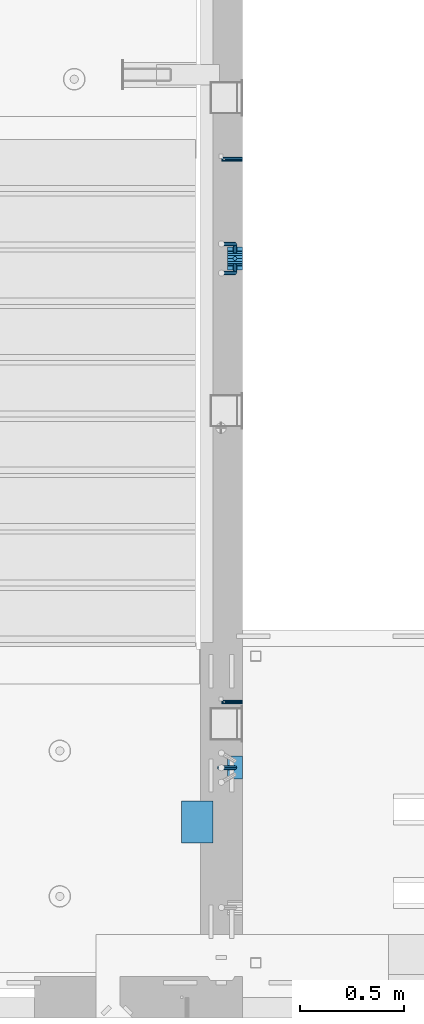
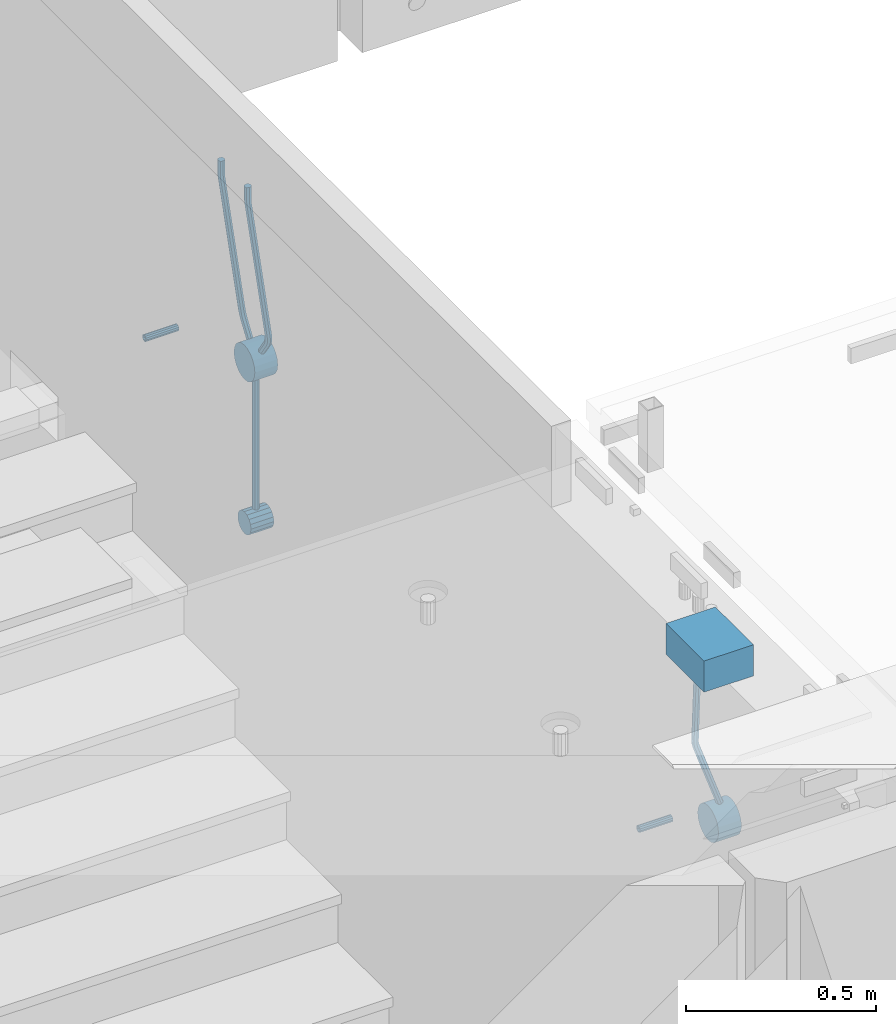
# One storey, part 104 of 264: 10 beams, 4 elements without a shape of their own.
"""IFC2X3 building model written with IfcOpenShell, lengths in millimetres."""

from ifc_helpers import new_model, si_unit, frame, origin_with_axes, place, context, subcontext, project, spatial, faceted_brep, material, type_object, element, aggregate, save


model = new_model("IFC2X3")

# Units and contexts
model_context = context("Model", 3, precision=1e-05, world=origin_with_axes())
body_context = subcontext(model_context, "Body", "Model", "MODEL_VIEW")
ifc_project = project(units=[si_unit("LENGTHUNIT", "METRE", prefix="MILLI"), si_unit("AREAUNIT", "SQUARE_METRE"), si_unit("VOLUMEUNIT", "CUBIC_METRE"), si_unit("MASSUNIT", "GRAM", prefix="KILO"), si_unit("TIMEUNIT", "SECOND"), si_unit("PLANEANGLEUNIT", "RADIAN"), si_unit("SOLIDANGLEUNIT", "STERADIAN"), si_unit("THERMODYNAMICTEMPERATUREUNIT", "DEGREE_CELSIUS"), si_unit("LUMINOUSINTENSITYUNIT", "LUMEN")], contexts=[model_context])

# Site, building, storey
site_placement = place(None, origin_with_axes())
site = spatial("IfcSite", under=ifc_project, at=site_placement, CompositionType="ELEMENT")
building_placement = place(site_placement, origin_with_axes())
building = spatial("IfcBuilding", under=site, at=building_placement, CompositionType="ELEMENT")
storey_placement = place(building_placement, origin_with_axes())
storey = spatial("IfcBuildingStorey", under=building, at=storey_placement, Name="K", CompositionType="ELEMENT", Elevation=0.0)

# Assemblies, beams
assembly_1_placement = place(storey_placement, origin_with_axes())
assembly_1 = element("IfcElementAssembly", 1, at=assembly_1_placement, inside=storey, AssemblyPlace="NOTDEFINED", PredefinedType="REINFORCEMENT_UNIT")
assembly_2_placement = place(assembly_1_placement, origin_with_axes())
assembly_2 = element("IfcElementAssembly", 2, at=assembly_2_placement, Name="Steel Assembly", AssemblyPlace="NOTDEFINED", PredefinedType="RIGID_FRAME")
ifc_material_1 = material(Name="STEEL/Steel_Undefined")
beam_type_1 = type_object("IfcBeamType", PredefinedType="NOTDEFINED")
beam_1_placement = place(assembly_2_placement, frame((22410.0, 19195.0015403676, 80575.0), z_axis=(0.0, 1.0, 0.0), x_axis=(-1.0, 3.00000001838171e-08, 0.0)))
beam_1 = element("IfcBeam", 3, at=beam_1_placement, type_object=beam_type_1, material=ifc_material_1, Name="M16", context=body_context, shape_type="Brep", body=[
    faceted_brep([(0.0, -8.49999999999272, -1.45519152283669e-11), (0.0, -7.36121593215648, 4.24999999998545), (100.000000000262, -7.36121593215648, 4.24999999998545), (100.000000000262, -8.49999999999272, -1.45519152283669e-11), (0.0, -4.24999999998545, 7.36121593216376), (100.000000000262, -4.24999999998545, 7.36121593216376), (0.0, 1.45519152283669e-11, 8.49999999998545), (100.000000000262, 1.45519152283669e-11, 8.49999999998545), (0.0, 4.25000000001455, 7.36121593216376), (100.000000000262, 4.25000000001455, 7.36121593216376), (0.0, 7.36121593217104, 4.24999999998545), (100.000000000262, 7.36121593217104, 4.24999999998545), (0.0, 8.50000000000728, 0.0), (100.000000000262, 8.50000000000728, 0.0), (0.0, 7.36121593217104, -4.25000000001455), (100.000000000262, 7.36121593217104, -4.25000000001455), (0.0, 4.25000000000728, -7.36121593219286), (100.000000000262, 4.25000000000728, -7.36121593219286), (0.0, 7.27595761418343e-12, -8.5), (100.000000000262, 7.27595761418343e-12, -8.5), (0.0, -4.24999999999272, -7.36121593217831), (100.000000000262, -4.24999999999272, -7.36121593217831), (0.0, -7.36121593215648, -4.25), (100.000000000262, -7.36121593215648, -4.25), (0.0, -10.4999999999927, -1.45519152283669e-11), (0.0, -9.09326673972828, -5.25000000001455), (100.000000000262, -9.09326673972828, -5.25000000001455), (100.000000000262, -10.4999999999927, -1.45519152283669e-11), (0.0, -5.24999999998545, -9.09326673974283), (100.000000000262, -5.24999999998545, -9.09326673974283), (0.0, 7.27595761418343e-12, -10.5), (100.000000000262, 7.27595761418343e-12, -10.5), (0.0, 5.25000000001455, -9.09326673975738), (100.000000000262, 5.25000000001455, -9.09326673975738), (0.0, 9.09326673975011, -5.25000000001455), (100.000000000262, 9.09326673975011, -5.25000000001455), (0.0, 10.5000000000073, -1.45519152283669e-11), (100.000000000262, 10.5000000000073, -1.45519152283669e-11), (0.0, 9.09326673975011, 5.25), (100.000000000262, 9.09326673975011, 5.25), (0.0, 5.25000000000728, 9.09326673972828), (100.000000000262, 5.25000000000728, 9.09326673972828), (0.0, 1.45519152283669e-11, 10.4999999999854), (100.000000000262, 1.45519152283669e-11, 10.4999999999854), (0.0, -5.24999999999272, 9.09326673972828), (100.000000000262, -5.24999999999272, 9.09326673972828), (0.0, -9.09326673972828, 5.24999999998545), (100.000000000262, -9.09326673972828, 5.24999999998545)], [[[0, 1, 2, 3]], [[1, 4, 5, 2]], [[4, 6, 7, 5]], [[6, 8, 9, 7]], [[8, 10, 11, 9]], [[10, 12, 13, 11]], [[12, 14, 15, 13]], [[14, 16, 17, 15]], [[16, 18, 19, 17]], [[18, 20, 21, 19]], [[20, 22, 23, 21]], [[22, 0, 3, 23]], [[24, 25, 26, 27]], [[25, 28, 29, 26]], [[28, 30, 31, 29]], [[30, 32, 33, 31]], [[32, 34, 35, 33]], [[34, 36, 37, 35]], [[36, 38, 39, 37]], [[38, 40, 41, 39]], [[40, 42, 43, 41]], [[42, 44, 45, 43]], [[44, 46, 47, 45]], [[46, 24, 27, 47]], [[29, 31, 33, 35, 37, 39, 41, 43, 45, 47, 27, 26], [5, 7, 9, 11, 13, 15, 17, 19, 21, 23, 3, 2]], [[46, 44, 42, 40, 38, 36, 34, 32, 30, 28, 25, 24], [22, 20, 18, 16, 14, 12, 10, 8, 6, 4, 1, 0]]]),
])
aggregate(assembly_2, [beam_1])
assembly_3_placement = place(assembly_1_placement, origin_with_axes())
assembly_3 = element("IfcElementAssembly", 4, at=assembly_3_placement, Name="Steel Assembly", AssemblyPlace="NOTDEFINED", PredefinedType="RIGID_FRAME")
beam_2_placement = place(assembly_3_placement, frame((22410.0, 16595.0015403676, 80575.0), z_axis=(0.0, -1.0, 0.0), x_axis=(-1.0, 3.00000001838171e-08, 0.0)))
beam_2 = element("IfcBeam", 5, at=beam_2_placement, type_object=beam_type_1, material=ifc_material_1, Name="M16", context=body_context, shape_type="Brep", body=[
    faceted_brep([(0.0, -8.49999999999272, -1.45519152283669e-11), (0.0, -7.36121593215648, 4.24999999998545), (100.000000000262, -7.36121593215648, 4.24999999998545), (100.000000000262, -8.49999999999272, -1.45519152283669e-11), (0.0, -4.24999999998545, 7.36121593216376), (100.000000000262, -4.24999999998545, 7.36121593216376), (0.0, 1.45519152283669e-11, 8.49999999998545), (100.000000000262, 1.45519152283669e-11, 8.49999999998545), (0.0, 4.25000000001455, 7.36121593216376), (100.000000000262, 4.25000000001455, 7.36121593216376), (0.0, 7.36121593217104, 4.24999999998545), (100.000000000262, 7.36121593217104, 4.24999999998545), (0.0, 8.50000000000728, 0.0), (100.000000000262, 8.50000000000728, 0.0), (0.0, 7.36121593217104, -4.25000000001455), (100.000000000262, 7.36121593217104, -4.25000000001455), (0.0, 4.25000000000728, -7.36121593219286), (100.000000000262, 4.25000000000728, -7.36121593219286), (0.0, 7.27595761418343e-12, -8.5), (100.000000000262, 7.27595761418343e-12, -8.5), (0.0, -4.24999999999272, -7.36121593217831), (100.000000000262, -4.24999999999272, -7.36121593217831), (0.0, -7.36121593215648, -4.25), (100.000000000262, -7.36121593215648, -4.25), (0.0, -10.4999999999927, -1.45519152283669e-11), (0.0, -9.09326673972828, -5.25000000001455), (100.000000000262, -9.09326673972828, -5.25000000001455), (100.000000000262, -10.4999999999927, -1.45519152283669e-11), (0.0, -5.24999999998545, -9.09326673974283), (100.000000000262, -5.24999999998545, -9.09326673974283), (0.0, 7.27595761418343e-12, -10.5), (100.000000000262, 7.27595761418343e-12, -10.5), (0.0, 5.25000000001455, -9.09326673975738), (100.000000000262, 5.25000000001455, -9.09326673975738), (0.0, 9.09326673975011, -5.25000000001455), (100.000000000262, 9.09326673975011, -5.25000000001455), (0.0, 10.5000000000073, -1.45519152283669e-11), (100.000000000262, 10.5000000000073, -1.45519152283669e-11), (0.0, 9.09326673975011, 5.25), (100.000000000262, 9.09326673975011, 5.25), (0.0, 5.25000000000728, 9.09326673972828), (100.000000000262, 5.25000000000728, 9.09326673972828), (0.0, 1.45519152283669e-11, 10.4999999999854), (100.000000000262, 1.45519152283669e-11, 10.4999999999854), (0.0, -5.24999999999272, 9.09326673972828), (100.000000000262, -5.24999999999272, 9.09326673972828), (0.0, -9.09326673972828, 5.24999999998545), (100.000000000262, -9.09326673972828, 5.24999999998545)], [[[0, 1, 2, 3]], [[1, 4, 5, 2]], [[4, 6, 7, 5]], [[6, 8, 9, 7]], [[8, 10, 11, 9]], [[10, 12, 13, 11]], [[12, 14, 15, 13]], [[14, 16, 17, 15]], [[16, 18, 19, 17]], [[18, 20, 21, 19]], [[20, 22, 23, 21]], [[22, 0, 3, 23]], [[24, 25, 26, 27]], [[25, 28, 29, 26]], [[28, 30, 31, 29]], [[30, 32, 33, 31]], [[32, 34, 35, 33]], [[34, 36, 37, 35]], [[36, 38, 39, 37]], [[38, 40, 41, 39]], [[40, 42, 43, 41]], [[42, 44, 45, 43]], [[44, 46, 47, 45]], [[46, 24, 27, 47]], [[29, 31, 33, 35, 37, 39, 41, 43, 45, 47, 27, 26], [5, 7, 9, 11, 13, 15, 17, 19, 21, 23, 3, 2]], [[46, 44, 42, 40, 38, 36, 34, 32, 30, 28, 25, 24], [22, 20, 18, 16, 14, 12, 10, 8, 6, 4, 1, 0]]]),
])
aggregate(assembly_3, [beam_2])
ifc_material_2 = material()
beam_type_2 = type_object("IfcBeamType", Name="D20", PredefinedType="NOTDEFINED")
beam_3_placement = place(assembly_1_placement, frame((22375.0, 18720.0024460395, 80295.0), z_axis=(-1.0, 3.00000001838171e-08, 0.0), x_axis=(0.0, 0.0, 1.0)))
beam_3 = element("IfcBeam", 6, at=beam_3_placement, type_object=beam_type_2, material=ifc_material_2, Name="JM20", ObjectType="D20", context=body_context, shape_type="Brep", body=[
    faceted_brep([(0.0, -10.0, 0.0), (-4.19531716033816e-08, -7.07106781186667, -7.07106781187031), (425.0, -7.07106781186667, -7.07106781186667), (425.0, -10.0, 0.0), (0.0, 0.0, -10.0), (425.0, 0.0, -10.0), (4.196772351861e-08, 7.07106781186303, -7.07106781186667), (425.0, 7.07106781186667, -7.07106781186667), (0.0, 10.0, 0.0), (425.0, 10.0, 0.0), (4.196772351861e-08, 7.07106781185939, 7.07106781185939), (425.0, 7.07106781186667, 7.07106781186667), (0.0, 0.0, 10.0), (425.0, 0.0, 10.0), (-4.19531716033816e-08, -7.07106781187031, 7.07106781185939), (425.0, -7.07106781186667, 7.07106781186667)], [[[0, 1, 2, 3]], [[1, 4, 5, 2]], [[4, 6, 7, 5]], [[6, 8, 9, 7]], [[8, 10, 11, 9]], [[10, 12, 13, 11]], [[12, 14, 15, 13]], [[14, 0, 3, 15]], [[5, 7, 9, 11, 13, 15, 3, 2]], [[14, 12, 10, 8, 6, 4, 1, 0]]]),
])
beam_4_placement = place(assembly_1_placement, frame((22375.0, 18687.6724460395, 80819.5), z_axis=(0.0, 0.827411434811092, 0.56159622287178), x_axis=(0.0, -0.561596222871772, 0.827411434811098)))
beam_4 = element("IfcBeam", 7, at=beam_4_placement, type_object=beam_type_2, material=ifc_material_2, Name="JM20", ObjectType="D20", context=body_context, shape_type="Brep", body=[
    faceted_brep([(0.0, -10.0, 0.0), (-4.19531716033816e-08, -7.07106781186667, -7.07106781187031), (51.3337046376182, -7.07106781186667, -7.07106782787741), (51.3337046409506, -9.99999999991269, -1.54977897182107e-08), (0.0, 0.0, -10.0), (51.3337046367014, 0.0, -10.0000000160071), (4.196772351861e-08, 7.07106781186303, -7.07106781186667), (51.3337046376182, 7.07106781186667, -7.07106782787741), (0.0, 10.0, 0.0), (51.3337046398156, 10.0, -1.60071067512035e-08), (4.196772351861e-08, 7.07106781185939, 7.07106781185939), (51.3337046420129, 7.07106781186667, 7.07106779584865), (0.0, 0.0, 10.0), (51.3337046429369, 0.0, 9.99999998399289), (-4.19531716033816e-08, -7.07106781187031, 7.07106781185939), (51.3337046420129, -7.07106781186667, 7.07106779584865), (69.2660488444162, -0.659091922268999, -7.32357754200348), (67.9041481351378, -7.68010393845179, -4.59791056146787), (65.6318046158776, -10.525517583621, 2.13400743270176), (63.7801263017391, -7.52852813498976, 8.92871018030564), (63.4338012359876, -0.444731365285406, 11.8059529640959), (64.7957019452297, 6.57628065089375, 9.08028598354576), (67.0680454645553, 9.4216942960702, 2.34836798937613), (68.9197237786866, 6.42470484744263, -4.44633475822775), (84.8821003096673, 4.54529190707035, 3.1855339796457), (85.5427757165526, -2.57551652551047, 0.458587145571073), (81.3497012897642, 7.74016969877266, 9.17665714836039), (77.0148100949955, 5.13760076933977, 14.9224379533844), (74.4167471958863, -1.73786529938297, 17.0570759255497), (75.0774226027788, -8.85867373196015, 14.3301290915115), (78.609821621445, -12.0535515238407, 8.3390059217345), (82.9447128173924, -9.45098259421866, 2.59322511772189), (456.104653264258, -71.822885658672, 255.871345609288), (451.769762084536, -74.4254545888944, 261.617126423276), (458.702716163367, -64.9474195899311, 253.736707637021), (458.042040756467, -57.8266111573103, 256.463654471001), (454.509641736608, -54.6317333655752, 262.454777639738), (450.174750541912, -57.2343022950008, 268.200558444849), (447.576687642802, -64.1097683637381, 270.335196417116), (448.237363049702, -71.2305767963589, 267.608249583143), (462.606852955585, -72.3637176989323, 260.284640654914), (458.569771733186, -74.9910575049726, 266.232556636794), (464.41816149011, -65.4228119344734, 257.616001989816), (462.942657378102, -58.2342286728781, 259.789892987465), (459.044670917043, -55.0089424945145, 265.532877784543), (455.007589709916, -57.6362823001473, 271.480793775474), (453.196281175427, -64.5771880646025, 274.149432440572), (454.671785287435, -71.7657713262015, 271.975541442938), (501.1302431886, -72.3637176993616, 286.431959314003), (497.093161981102, -74.9910575049726, 292.379875304716), (502.941551724049, -65.4228119349536, 283.763320649487), (501.466047613016, -58.2342286733801, 285.93721164779), (497.568061152415, -55.0089424950274, 291.680196445202), (493.530979944895, -57.6362823006384, 297.628112435916), (491.719671409453, -64.5771880650464, 300.296751100424), (493.195175520486, -71.7657713266199, 298.122860102128)], [[[0, 1, 2, 3]], [[1, 4, 5, 2]], [[4, 6, 7, 5]], [[6, 8, 9, 7]], [[8, 10, 11, 9]], [[10, 12, 13, 11]], [[12, 14, 15, 13]], [[14, 0, 3, 15]], [[14, 12, 10, 8, 6, 4, 1, 0]], [[2, 5, 16, 17]], [[3, 2, 17, 18]], [[15, 3, 18, 19]], [[13, 15, 19, 20]], [[11, 13, 20, 21]], [[9, 11, 21, 22]], [[7, 9, 22, 23]], [[5, 7, 23, 16]], [[23, 24, 25, 16]], [[22, 26, 24, 23]], [[21, 27, 26, 22]], [[20, 28, 27, 21]], [[19, 29, 28, 20]], [[18, 30, 29, 19]], [[17, 31, 30, 18]], [[16, 25, 31, 17]], [[30, 31, 32, 33]], [[31, 25, 34, 32]], [[25, 24, 35, 34]], [[24, 26, 36, 35]], [[26, 27, 37, 36]], [[27, 28, 38, 37]], [[28, 29, 39, 38]], [[29, 30, 33, 39]], [[33, 32, 40, 41]], [[32, 34, 42, 40]], [[34, 35, 43, 42]], [[35, 36, 44, 43]], [[36, 37, 45, 44]], [[37, 38, 46, 45]], [[38, 39, 47, 46]], [[39, 33, 41, 47]], [[41, 40, 48, 49]], [[40, 42, 50, 48]], [[42, 43, 51, 50]], [[43, 44, 52, 51]], [[44, 45, 53, 52]], [[45, 46, 54, 53]], [[46, 47, 55, 54]], [[47, 41, 49, 55]], [[50, 51, 52, 53, 54, 55, 49, 48]]]),
])
beam_5_placement = place(assembly_1_placement, frame((22375.0, 18752.3324460395, 80819.5), z_axis=(0.0, -0.827411461133416, 0.561596184090549), x_axis=(0.0, 0.561596184090567, 0.827411461133404)))
beam_5 = element("IfcBeam", 8, at=beam_5_placement, type_object=beam_type_2, material=ifc_material_2, Name="JM20", ObjectType="D20", context=body_context, shape_type="Brep", body=[
    faceted_brep([(0.0, -10.0, 0.0), (-4.19531716033816e-08, -7.07106781186667, -7.07106781187031), (51.3337046376182, -7.07106781186667, -7.07106782787741), (51.3337046409506, -9.99999999991269, -1.54977897182107e-08), (0.0, 0.0, -10.0), (51.3337046367014, 0.0, -10.0000000160071), (4.196772351861e-08, 7.07106781186303, -7.07106781186667), (51.3337046376182, 7.07106781186667, -7.07106782787741), (0.0, 10.0, 0.0), (51.3337046398156, 10.0, -1.60071067512035e-08), (4.196772351861e-08, 7.07106781185939, 7.07106781185939), (51.3337046420129, 7.07106781186667, 7.07106779584865), (0.0, 0.0, 10.0), (51.3337046429369, 0.0, 9.99999998399289), (-4.19531716033816e-08, -7.07106781187031, 7.07106781185939), (51.3337046420129, -7.07106781186667, 7.07106779584865), (69.2660466430243, 0.659091867106326, -7.32357794087511), (68.9197216384055, -6.42470490018968, -4.4463351438535), (67.0680434794049, -9.4216943423271, 2.34836764901047), (64.7957001183095, -6.57628069041675, 9.08028569392627), (63.4337994777306, 0.444731328843773, 11.8059527009682), (63.7801244823058, 7.5285280961325, 8.92870990392839), (65.6318026413501, 10.5255175382845, 2.1340071110717), (67.9041460024164, 7.68010388636321, -4.59791093384047), (82.9447097816592, 9.45098239876097, 2.5932236664521), (85.5427725682093, 2.57551631875685, 0.458585593522002), (78.6098188586766, 12.0535513533796, 8.33900466527484), (75.0774201104796, 8.85867358599717, 14.3301280072737), (74.4167448160297, 1.73786516263135, 17.0570748925675), (77.0148076025362, -5.13760091737277, 14.9224368196265), (81.3496985272359, -7.74016987211508, 9.17665582116388), (84.8820972737449, -4.54529210461624, 3.18553247882301), (458.042050619828, 57.8266111314697, 256.463636177414), (454.509651863089, 54.6317333639417, 262.454759522334), (458.702725914249, 64.9474195548719, 253.736689292113), (456.104663127713, 71.8228856349233, 255.87132736493), (451.769772204658, 74.4254545895674, 261.61710836356), (448.237373456403, 71.230576822185, 267.608231705432), (447.576698161967, 64.1097683987828, 270.335178590722), (450.174760948517, 57.2343023187277, 268.200540517912), (462.942667372816, 58.2342286474559, 259.789874457503), (459.044681183615, 55.0089424935286, 265.532859444185), (464.418171395897, 65.4228118997271, 257.615983368723), (462.606862999062, 72.3637176755656, 260.284622097595), (458.569782075458, 74.991057506646, 266.2325382698), (454.671795877803, 71.7657713528824, 271.975523259531), (453.196291854692, 64.5771881006112, 274.149414348289), (455.007600251556, 57.6362823247728, 271.480775619417), (501.466058854465, 58.2342286472995, 285.937191316629), (497.568072656635, 55.0089424935286, 291.680176306199), (502.94156287791, 65.422811899567, 283.763300228111), (501.130254481352, 72.3637176753982, 286.431938957172), (497.093173557863, 74.9910575064714, 292.379855129409), (493.195187360005, 71.7657713527005, 298.122840118976), (491.71968333656, 64.577188100433, 300.296731207494), (493.530991733118, 57.6362823246018, 297.62809247843)], [[[0, 1, 2, 3]], [[1, 4, 5, 2]], [[4, 6, 7, 5]], [[6, 8, 9, 7]], [[8, 10, 11, 9]], [[10, 12, 13, 11]], [[12, 14, 15, 13]], [[14, 0, 3, 15]], [[14, 12, 10, 8, 6, 4, 1, 0]], [[2, 5, 16, 17]], [[3, 2, 17, 18]], [[15, 3, 18, 19]], [[13, 15, 19, 20]], [[11, 13, 20, 21]], [[9, 11, 21, 22]], [[7, 9, 22, 23]], [[5, 7, 23, 16]], [[23, 24, 25, 16]], [[22, 26, 24, 23]], [[21, 27, 26, 22]], [[20, 28, 27, 21]], [[19, 29, 28, 20]], [[18, 30, 29, 19]], [[17, 31, 30, 18]], [[16, 25, 31, 17]], [[30, 31, 32, 33]], [[31, 25, 34, 32]], [[25, 24, 35, 34]], [[24, 26, 36, 35]], [[26, 27, 37, 36]], [[27, 28, 38, 37]], [[28, 29, 39, 38]], [[29, 30, 33, 39]], [[33, 32, 40, 41]], [[32, 34, 42, 40]], [[34, 35, 43, 42]], [[35, 36, 44, 43]], [[36, 37, 45, 44]], [[37, 38, 46, 45]], [[38, 39, 47, 46]], [[39, 33, 41, 47]], [[41, 40, 48, 49]], [[40, 42, 50, 48]], [[42, 43, 51, 50]], [[43, 44, 52, 51]], [[44, 45, 53, 52]], [[45, 46, 54, 53]], [[46, 47, 55, 54]], [[47, 41, 49, 55]], [[50, 51, 52, 53, 54, 55, 49, 48]]]),
])
beam_6_placement = place(assembly_1_placement, frame((22375.0, 16280.0024460395, 80830.0), z_axis=(0.944200181496404, 0.0, 0.329372156173162), x_axis=(-0.329372156173166, 0.0, 0.944200181496403)))
beam_6 = element("IfcBeam", 9, at=beam_6_placement, type_object=beam_type_2, material=ifc_material_2, Name="JM20", ObjectType="D20", context=body_context, shape_type="Brep", body=[
    faceted_brep([(0.0, -10.0, 0.0), (-4.19531716033816e-08, -7.07106781186667, -7.07106781187031), (218.375878367413, -7.07106781186485, -7.07106784576172), (218.375878363455, -10.0, -3.29600879922509e-08), (0.0, 0.0, -10.0), (218.375878366962, 0.0, -10.0000000338914), (4.196772351861e-08, 7.07106781186303, -7.07106781186667), (218.375878367413, 7.07106781186485, -7.07106784576172), (0.0, 10.0, 0.0), (218.375878368504, 10.0, -3.38914105668664e-08), (4.196772351861e-08, 7.07106781185939, 7.07106781185939), (218.37587836961, 7.07106781186485, 7.07106777796434), (0.0, 0.0, 10.0), (218.375878370061, 0.0, 9.99999996610859), (-4.19531716033816e-08, -7.07106781187031, 7.07106781185939), (218.37587836961, -7.07106781186485, 7.07106777796434), (229.381987888177, 0.0, -8.98190872837586), (228.844718747816, -7.07106781186485, -6.10267521342757), (227.547636302465, -10.0, 0.848409387603169), (226.250553857099, -7.07106781186485, 7.79949398861208), (225.713284716709, 0.0, 10.6787275035531), (226.250553857099, 7.07106781186485, 7.79949398861208), (227.547636302465, 10.0, 0.848409387603169), (228.844718747816, 7.07106781186485, -6.10267521342757), (238.958284621054, 7.07106781186485, -3.23036105215579), (240.014589934406, 0.0, -5.96218514016073), (236.408138007595, 10.0, 3.36484571110486), (233.857991394121, 7.07106781186485, 9.96005247439462), (232.80168608074, 0.0, 12.6918765623923), (233.857991394121, -7.07106781186485, 9.96005247439462), (236.408138013285, -10.0, 3.36484571115579), (238.958284621054, -7.07106781186485, -3.23036105215579), (509.445393446338, -7.07106781186485, 101.35798764378), (506.895246820757, -10.0, 107.953194408758), (510.50169875985, 0.0, 98.6261635558694), (509.445393446338, 7.07106781186485, 101.35798764378), (506.895246832442, 10.0, 107.953194406851), (504.345100218547, 7.07106781186485, 114.548401169923), (503.288794905049, 0.0, 117.280225257848), (504.345100218547, -7.07106781186485, 114.548401169923), (510.787911501408, -7.07106781186485, 101.851545717676), (508.4588986608, -10.0, 108.528049226727), (511.752620211773, 0.0, 99.0860474141373), (510.787911501408, 7.07106781186485, 101.851545717676), (508.458898649114, 10.0, 108.528049228822), (506.129885796938, 7.07106781186485, 115.204552739997), (505.165177086586, 0.0, 117.970051043558), (506.129885796938, -7.07106781186485, 115.204552739997), (557.211305545992, -7.07106781186485, 118.045752928381), (554.882292694339, -10.0, 124.722256439716), (558.176014256082, 0.0, 115.280254624755), (557.211305545992, 7.07106781186485, 118.045752928381), (554.882292694339, 10.0, 124.722256439716), (552.553279842701, 7.07106781186485, 131.398759951058), (551.588571132612, 0.0, 134.164258254685), (552.553279842701, -7.07106781186485, 131.398759951058)], [[[0, 1, 2, 3]], [[1, 4, 5, 2]], [[4, 6, 7, 5]], [[6, 8, 9, 7]], [[8, 10, 11, 9]], [[10, 12, 13, 11]], [[12, 14, 15, 13]], [[14, 0, 3, 15]], [[14, 12, 10, 8, 6, 4, 1, 0]], [[2, 5, 16, 17]], [[3, 2, 17, 18]], [[15, 3, 18, 19]], [[13, 15, 19, 20]], [[11, 13, 20, 21]], [[9, 11, 21, 22]], [[7, 9, 22, 23]], [[5, 7, 23, 16]], [[23, 24, 25, 16]], [[22, 26, 24, 23]], [[21, 27, 26, 22]], [[20, 28, 27, 21]], [[19, 29, 28, 20]], [[18, 30, 29, 19]], [[17, 31, 30, 18]], [[16, 25, 31, 17]], [[30, 31, 32, 33]], [[31, 25, 34, 32]], [[25, 24, 35, 34]], [[24, 26, 36, 35]], [[26, 27, 37, 36]], [[27, 28, 38, 37]], [[28, 29, 39, 38]], [[29, 30, 33, 39]], [[33, 32, 40, 41]], [[32, 34, 42, 40]], [[34, 35, 43, 42]], [[35, 36, 44, 43]], [[36, 37, 45, 44]], [[37, 38, 46, 45]], [[38, 39, 47, 46]], [[39, 33, 41, 47]], [[41, 40, 48, 49]], [[40, 42, 50, 48]], [[42, 43, 51, 50]], [[43, 44, 52, 51]], [[44, 45, 53, 52]], [[45, 46, 54, 53]], [[46, 47, 55, 54]], [[47, 41, 49, 55]], [[50, 51, 52, 53, 54, 55, 49, 48]]]),
])
beam_type_3 = type_object("IfcBeamType", Name="D70", PredefinedType="NOTDEFINED")
beam_7_placement = place(assembly_1_placement, frame((22410.0, 18720.0024460367, 80260.0), z_axis=(0.0, 0.0, 1.0), x_axis=(-1.0, 3.00000001838171e-08, 0.0)))
beam_7 = element("IfcBeam", 10, at=beam_7_placement, type_object=beam_type_3, material=ifc_material_2, ObjectType="D70", context=body_context, shape_type="Brep", body=[
    faceted_brep([(0.0, -35.0, 0.0), (0.0, -32.3357836378964, -13.3939201327739), (70.0, -32.3357836378964, -13.3939201327739), (70.0, -35.0, 0.0), (0.0, -24.7487373415279, -24.7487373415352), (70.0, -24.7487373415279, -24.7487373415352), (0.0, -13.3939201327776, -32.3357836379), (70.0, -13.3939201327776, -32.3357836379), (0.0, 0.0, -35.0), (70.0, 0.0, -35.0), (0.0, 13.3939201327776, -32.3357836379), (70.0, 13.3939201327776, -32.3357836379), (0.0, 24.7487373415279, -24.7487373415352), (70.0, 24.7487373415279, -24.7487373415352), (0.0, 32.3357836378964, -13.3939201327739), (70.0, 32.3357836378964, -13.3939201327739), (0.0, 35.0, 0.0), (70.0, 35.0, 0.0), (0.0, 32.3357836378964, 13.3939201327739), (70.0, 32.3357836378964, 13.3939201327739), (0.0, 24.7487373415279, 24.7487373415352), (70.0, 24.7487373415279, 24.7487373415352), (0.0, 13.3939201327776, 32.3357836379), (70.0, 13.3939201327776, 32.3357836379), (0.0, 0.0, 35.0), (70.0, 0.0, 35.0), (0.0, -13.3939201327776, 32.3357836379), (70.0, -13.3939201327776, 32.3357836379), (0.0, -24.7487373415279, 24.7487373415352), (70.0, -24.7487373415279, 24.7487373415352), (0.0, -32.3357836378964, 13.3939201327739), (70.0, -32.3357836378964, 13.3939201327739)], [[[0, 1, 2, 3]], [[1, 4, 5, 2]], [[4, 6, 7, 5]], [[6, 8, 9, 7]], [[8, 10, 11, 9]], [[10, 12, 13, 11]], [[12, 14, 15, 13]], [[14, 16, 17, 15]], [[16, 18, 19, 17]], [[18, 20, 21, 19]], [[20, 22, 23, 21]], [[22, 24, 25, 23]], [[24, 26, 27, 25]], [[26, 28, 29, 27]], [[28, 30, 31, 29]], [[30, 0, 3, 31]], [[5, 7, 9, 11, 13, 15, 17, 19, 21, 23, 25, 27, 29, 31, 3, 2]], [[30, 28, 26, 24, 22, 20, 18, 16, 14, 12, 10, 8, 6, 4, 1, 0]]]),
])
beam_type_4 = type_object("IfcBeamType", Name="D110", PredefinedType="NOTDEFINED")
beam_8_placement = place(assembly_1_placement, frame((22410.0, 18720.0015915445, 80775.0), z_axis=(0.0, 0.0, 1.0), x_axis=(-1.0, 3.00000001838171e-08, 0.0)))
beam_8 = element("IfcBeam", 11, at=beam_8_placement, type_object=beam_type_4, material=ifc_material_2, ObjectType="D110", context=body_context, shape_type="Brep", body=[
    faceted_brep([(0.0, -55.0, 0.0), (0.0, -52.3081083962352, -16.9959346906253), (70.0, -52.3081083962352, -16.9959346906253), (70.0, -55.0, 0.0), (0.0, -44.4959346906217, -32.328188876083), (70.0, -44.4959346906217, -32.328188876083), (0.0, -32.3281888760866, -44.4959346906253), (70.0, -32.3281888760866, -44.4959346906253), (0.0, -16.9959346906217, -52.3081083962315), (70.0, -16.9959346906217, -52.3081083962315), (0.0, 0.0, -55.0), (70.0, 0.0, -55.0), (0.0, 16.9959346906217, -52.3081083962315), (70.0, 16.9959346906217, -52.3081083962315), (0.0, 32.3281888760866, -44.4959346906253), (70.0, 32.3281888760866, -44.4959346906253), (0.0, 44.4959346906217, -32.328188876083), (70.0, 44.4959346906217, -32.328188876083), (0.0, 52.3081083962352, -16.9959346906253), (70.0, 52.3081083962352, -16.9959346906253), (0.0, 55.0, 0.0), (70.0, 55.0, 0.0), (0.0, 52.3081083962352, 16.9959346906253), (70.0, 52.3081083962352, 16.9959346906253), (0.0, 44.4959346906217, 32.328188876083), (70.0, 44.4959346906217, 32.328188876083), (0.0, 32.3281888760866, 44.4959346906253), (70.0, 32.3281888760866, 44.4959346906253), (0.0, 16.9959346906217, 52.3081083962315), (70.0, 16.9959346906217, 52.3081083962315), (0.0, 0.0, 55.0), (70.0, 0.0, 55.0), (0.0, -16.9959346906217, 52.3081083962315), (70.0, -16.9959346906217, 52.3081083962315), (0.0, -32.3281888760866, 44.4959346906253), (70.0, -32.3281888760866, 44.4959346906253), (0.0, -44.4959346906217, 32.328188876083), (70.0, -44.4959346906217, 32.328188876083), (0.0, -52.3081083962352, 16.9959346906253), (70.0, -52.3081083962352, 16.9959346906253)], [[[0, 1, 2, 3]], [[1, 4, 5, 2]], [[4, 6, 7, 5]], [[6, 8, 9, 7]], [[8, 10, 11, 9]], [[10, 12, 13, 11]], [[12, 14, 15, 13]], [[14, 16, 17, 15]], [[16, 18, 19, 17]], [[18, 20, 21, 19]], [[20, 22, 23, 21]], [[22, 24, 25, 23]], [[24, 26, 27, 25]], [[26, 28, 29, 27]], [[28, 30, 31, 29]], [[30, 32, 33, 31]], [[32, 34, 35, 33]], [[34, 36, 37, 35]], [[36, 38, 39, 37]], [[38, 0, 3, 39]], [[5, 7, 9, 11, 13, 15, 17, 19, 21, 23, 25, 27, 29, 31, 33, 35, 37, 39, 3, 2]], [[38, 36, 34, 32, 30, 28, 26, 24, 22, 20, 18, 16, 14, 12, 10, 8, 6, 4, 1, 0]]]),
])
beam_9_placement = place(assembly_1_placement, frame((22410.0, 16280.0015915445, 80775.0), z_axis=(0.0, 0.0, 1.0), x_axis=(-1.0, 3.00000001838171e-08, 0.0)))
beam_9 = element("IfcBeam", 12, at=beam_9_placement, type_object=beam_type_4, material=ifc_material_2, ObjectType="D110", context=body_context, shape_type="Brep", body=[
    faceted_brep([(0.0, -55.0, 0.0), (0.0, -52.3081083962352, -16.9959346906253), (70.0, -52.3081083962352, -16.9959346906253), (70.0, -55.0, 0.0), (0.0, -44.4959346906217, -32.328188876083), (70.0, -44.4959346906217, -32.328188876083), (0.0, -32.3281888760866, -44.4959346906253), (70.0, -32.3281888760866, -44.4959346906253), (0.0, -16.9959346906217, -52.3081083962315), (70.0, -16.9959346906217, -52.3081083962315), (0.0, 0.0, -55.0), (70.0, 0.0, -55.0), (0.0, 16.9959346906217, -52.3081083962315), (70.0, 16.9959346906217, -52.3081083962315), (0.0, 32.3281888760866, -44.4959346906253), (70.0, 32.3281888760866, -44.4959346906253), (0.0, 44.4959346906217, -32.328188876083), (70.0, 44.4959346906217, -32.328188876083), (0.0, 52.3081083962352, -16.9959346906253), (70.0, 52.3081083962352, -16.9959346906253), (0.0, 55.0, 0.0), (70.0, 55.0, 0.0), (0.0, 52.3081083962352, 16.9959346906253), (70.0, 52.3081083962352, 16.9959346906253), (0.0, 44.4959346906217, 32.328188876083), (70.0, 44.4959346906217, 32.328188876083), (0.0, 32.3281888760866, 44.4959346906253), (70.0, 32.3281888760866, 44.4959346906253), (0.0, 16.9959346906217, 52.3081083962315), (70.0, 16.9959346906217, 52.3081083962315), (0.0, 0.0, 55.0), (70.0, 0.0, 55.0), (0.0, -16.9959346906217, 52.3081083962315), (70.0, -16.9959346906217, 52.3081083962315), (0.0, -32.3281888760866, 44.4959346906253), (70.0, -32.3281888760866, 44.4959346906253), (0.0, -44.4959346906217, 32.328188876083), (70.0, -44.4959346906217, 32.328188876083), (0.0, -52.3081083962352, 16.9959346906253), (70.0, -52.3081083962352, 16.9959346906253)], [[[0, 1, 2, 3]], [[1, 4, 5, 2]], [[4, 6, 7, 5]], [[6, 8, 9, 7]], [[8, 10, 11, 9]], [[10, 12, 13, 11]], [[12, 14, 15, 13]], [[14, 16, 17, 15]], [[16, 18, 19, 17]], [[18, 20, 21, 19]], [[20, 22, 23, 21]], [[22, 24, 25, 23]], [[24, 26, 27, 25]], [[26, 28, 29, 27]], [[28, 30, 31, 29]], [[30, 32, 33, 31]], [[32, 34, 35, 33]], [[34, 36, 37, 35]], [[36, 38, 39, 37]], [[38, 0, 3, 39]], [[5, 7, 9, 11, 13, 15, 17, 19, 21, 23, 25, 27, 29, 31, 33, 35, 37, 39, 3, 2]], [[38, 36, 34, 32, 30, 28, 26, 24, 22, 20, 18, 16, 14, 12, 10, 8, 6, 4, 1, 0]]]),
])
aggregate(assembly_1, [beam_3, beam_4, beam_5, beam_6, beam_8, beam_7, beam_9, assembly_2, assembly_3])

# Assembly, beam
assembly_4_placement = place(storey_placement, origin_with_axes())
assembly_4 = element("IfcElementAssembly", 13, at=assembly_4_placement, inside=storey, AssemblyPlace="NOTDEFINED", PredefinedType="REINFORCEMENT_UNIT")
beam_type_5 = type_object("IfcBeamType", Name="200X100", PredefinedType="NOTDEFINED")
beam_10_placement = place(assembly_4_placement, frame((22120.0202472815, 16019.9974492144, 81540.0), z_axis=(1.19800000174933e-06, -0.999999999999282, 0.0), x_axis=(0.999999999999282, 1.19800000174933e-06, 0.0)))
beam_10 = element("IfcBeam", 14, at=beam_10_placement, type_object=beam_type_5, material=ifc_material_2, Name="W1", ObjectType="200X100", context=body_context, shape_type="Brep", body=[
    faceted_brep([(0.0, 50.0, -100.0), (0.0, 50.0, 100.0), (150.0, 50.0, 100.0), (150.0, 50.0, -100.0), (0.0, -50.0, 100.0), (150.0, -50.0, 100.0), (0.0, -50.0, -100.0), (150.0, -50.0, -100.0)], [[[0, 1, 2, 3]], [[1, 4, 5, 2]], [[4, 6, 7, 5]], [[6, 0, 3, 7]], [[5, 7, 3, 2]], [[6, 4, 1, 0]]]),
])
aggregate(assembly_4, [beam_10])

save(model, "model.ifc")
